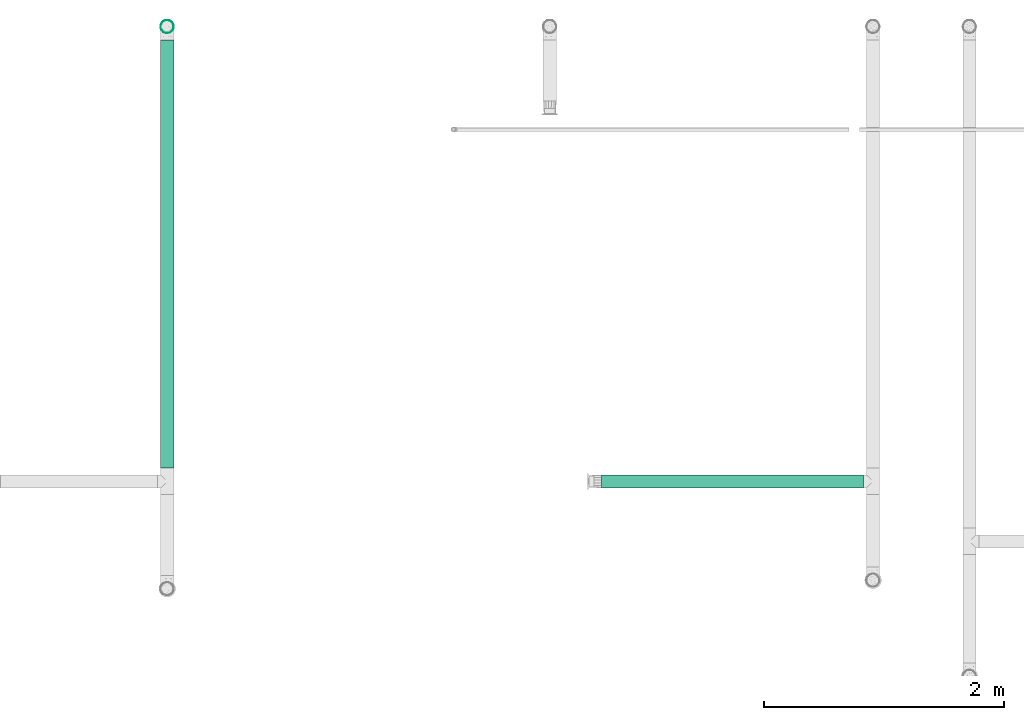
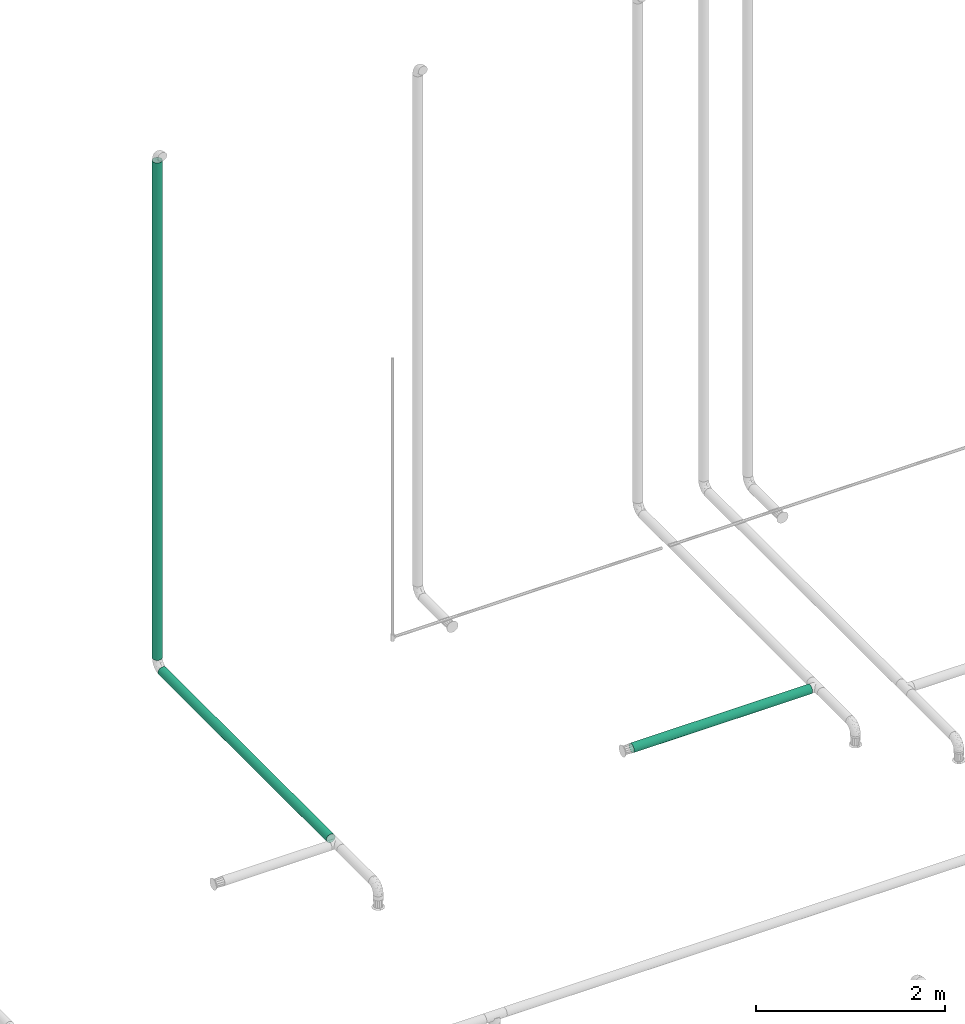
# One storey, part 7 of 123: 3 flow segments.
"""IFC2X3 building model written with IfcOpenShell, lengths in millimetres."""

from ifc_helpers import new_model, entity, si_unit, converted_unit, derived_unit, direction, frame, origin_with_axes, origin_2d_with_axis, place, context, subcontext, project, spatial, hollow_circle, extrude, source, transform, mapped, material, layer, layer_set, layer_usage, type_object, element, save


model = new_model("IFC2X3")

# Units and contexts
model_context = context("Model", 3, precision=1e-05, world=origin_with_axes(), true_north=direction((0.0, 1.0)))
body_context = subcontext(model_context, "Body", "Model", "MODEL_VIEW")
ifc_project = project(units=[si_unit("AREAUNIT", "SQUARE_METRE"), si_unit("VOLUMEUNIT", "CUBIC_METRE", prefix="DECI"), si_unit("TIMEUNIT", "SECOND"), si_unit("THERMODYNAMICTEMPERATUREUNIT", "DEGREE_CELSIUS"), si_unit("PRESSUREUNIT", "PASCAL"), si_unit("MASSUNIT", "GRAM", prefix="KILO"), si_unit("LENGTHUNIT", "METRE", prefix="MILLI"), si_unit("POWERUNIT", "WATT"), si_unit("ELECTRICCURRENTUNIT", "AMPERE"), si_unit("ELECTRICVOLTAGEUNIT", "VOLT"), derived_unit("VOLUMETRICFLOWRATEUNIT", [(si_unit("VOLUMEUNIT", "CUBIC_METRE", prefix="DECI"), 1), (si_unit("TIMEUNIT", "SECOND"), -1)]), derived_unit("LINEARVELOCITYUNIT", [(si_unit("LENGTHUNIT", "METRE"), 1), (si_unit("TIMEUNIT", "SECOND"), -1)]), derived_unit("MASSDENSITYUNIT", [(si_unit("MASSUNIT", "GRAM", prefix="KILO"), 1), (si_unit("VOLUMEUNIT", "CUBIC_METRE"), -1)]), converted_unit("PLANEANGLEUNIT", "DEGREE", entity("IfcRatioMeasure", 0.01745), si_unit("PLANEANGLEUNIT", "RADIAN"), dimensions=[0, 0, 0, 0, 0, 0, 0])], contexts=[model_context])

# Site, building, storey
site_placement = place(None, origin_with_axes())
site = spatial("IfcSite", under=ifc_project, at=site_placement, CompositionType="ELEMENT")
building_placement = place(site_placement, origin_with_axes())
building = spatial("IfcBuilding", under=site, at=building_placement, Name="mc-building", CompositionType="ELEMENT")
storey_placement = place(building_placement, origin_with_axes())
storey = spatial("IfcBuildingStorey", under=building, at=storey_placement, Name="1. Korrus", CompositionType="ELEMENT", Elevation=0.0)

# Flow segments
ifc_material = material(Name="FZ1")
ifc_layer = layer(ifc_material, 0.0)
ifc_layer_set = layer_set([ifc_layer], Name="FZ1")
ifc_layer_usage = layer_usage(ifc_layer_set, "AXIS1", "POSITIVE", 0.0)
duct_segment_type = type_object("IfcDuctSegmentType", PredefinedType="RIGIDSEGMENT")
shared_shape_1 = source(origin_with_axes(), body_context, "Body", "SweptSolid", [
    extrude(hollow_circle(Radius=55.0, WallThickness=2.0, at=origin_2d_with_axis()), frame((0.0, 0.0, 0.0), z_axis=(1.0, 0.0, 0.0), x_axis=(0.0, 1.0, 0.0)), (0.0, 0.0, 1.0), 3565.9),
])
flow_segment_1_placement = place(storey_placement, frame((12366.76802, 13553.57591, 2465.0), z_axis=(0.0, 0.0, 1.0), x_axis=(0.0, -1.0, 0.0)))
element("IfcFlowSegment", 1, at=flow_segment_1_placement, inside=storey, type_object=duct_segment_type, material=ifc_layer_usage, context=body_context, shape_type="MappedRepresentation", body=[
    mapped(shared_shape_1, transform((0.0, 0.0, 0.0), scale=1.0)),
])
shared_shape_2 = source(origin_with_axes(), body_context, "Body", "SweptSolid", [
    extrude(hollow_circle(Radius=55.0, WallThickness=2.0, at=origin_2d_with_axis()), frame((0.0, 0.0, 0.0), z_axis=(1.0, 0.0, 0.0), x_axis=(0.0, 1.0, 0.0)), (0.0, 0.0, 1.0), 6430.0),
])
flow_segment_2_placement = place(storey_placement, frame((12366.76802, 13663.57591, 2575.0), z_axis=(0.0, -1.0, 0.0), x_axis=(0.0, 0.0, 1.0)))
element("IfcFlowSegment", 2, at=flow_segment_2_placement, inside=storey, type_object=duct_segment_type, material=ifc_layer_usage, context=body_context, shape_type="MappedRepresentation", body=[
    mapped(shared_shape_2, transform((0.0, 0.0, 0.0), scale=1.0)),
])
shared_shape_3 = source(origin_with_axes(), body_context, "Body", "SweptSolid", [
    extrude(hollow_circle(Radius=55.0, WallThickness=2.0, at=origin_2d_with_axis()), frame((0.0, 0.0, 0.0), z_axis=(1.0, 0.0, 0.0), x_axis=(0.0, 1.0, 0.0)), (0.0, 0.0, 1.0), 2181.3),
])
flow_segment_3_placement = place(storey_placement, frame((18162.77608, 9877.62755, 2435.0), z_axis=(0.0, 0.0, 1.0), x_axis=(-1.0, 0.0, 0.0)))
element("IfcFlowSegment", 3, at=flow_segment_3_placement, inside=storey, type_object=duct_segment_type, material=ifc_layer_usage, context=body_context, shape_type="MappedRepresentation", body=[
    mapped(shared_shape_3, transform((0.0, 0.0, 0.0), scale=1.0)),
])

save(model, "model.ifc")
